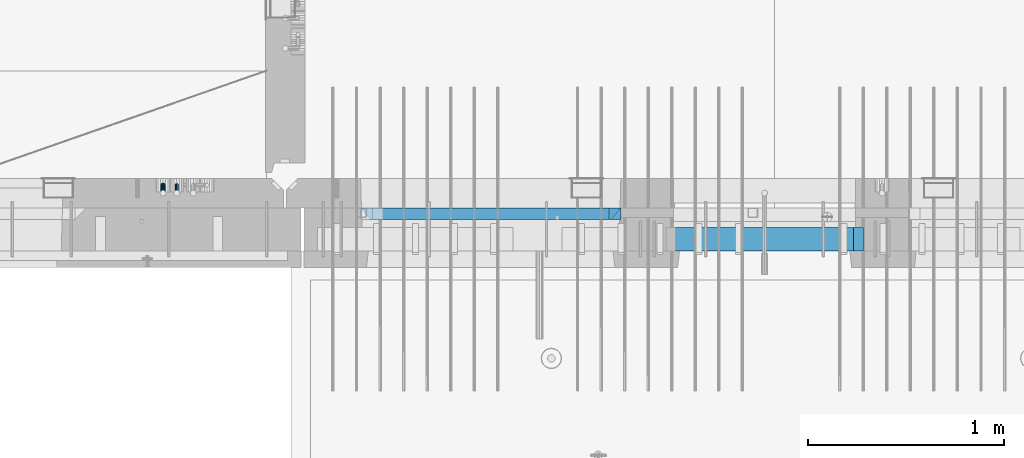
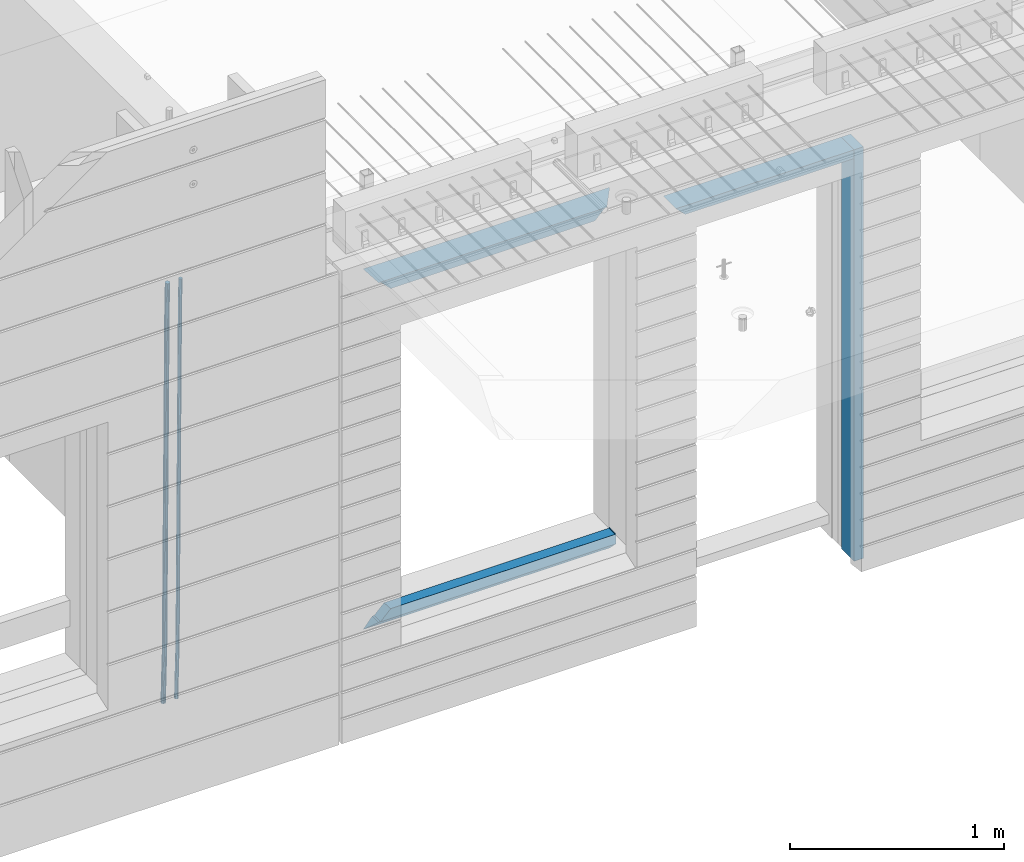
# One storey, part 79 of 309: 8 beams, 2 elements without a shape of their own.
"""IFC2X3 building model written with IfcOpenShell, lengths in millimetres."""

from ifc_helpers import new_model, si_unit, frame, origin_with_axes, place, context, subcontext, project, spatial, faceted_brep, material, type_object, element, aggregate, save


model = new_model("IFC2X3")

# Units and contexts
model_context = context("Model", 3, precision=1e-05, world=origin_with_axes())
body_context = subcontext(model_context, "Body", "Model", "MODEL_VIEW")
ifc_project = project(units=[si_unit("LENGTHUNIT", "METRE", prefix="MILLI"), si_unit("AREAUNIT", "SQUARE_METRE"), si_unit("VOLUMEUNIT", "CUBIC_METRE"), si_unit("MASSUNIT", "GRAM", prefix="KILO"), si_unit("TIMEUNIT", "SECOND"), si_unit("PLANEANGLEUNIT", "RADIAN"), si_unit("SOLIDANGLEUNIT", "STERADIAN"), si_unit("THERMODYNAMICTEMPERATUREUNIT", "DEGREE_CELSIUS"), si_unit("LUMINOUSINTENSITYUNIT", "LUMEN")], contexts=[model_context])

# Site, building, storey
site_placement = place(None, origin_with_axes())
site = spatial("IfcSite", under=ifc_project, at=site_placement, CompositionType="ELEMENT")
building_placement = place(site_placement, origin_with_axes())
building = spatial("IfcBuilding", under=site, at=building_placement, CompositionType="ELEMENT")
storey_placement = place(building_placement, origin_with_axes())
storey = spatial("IfcBuildingStorey", under=building, at=storey_placement, Name="7", CompositionType="ELEMENT", Elevation=0.0)

# Assembly, beams
assembly_1_placement = place(storey_placement, origin_with_axes())
assembly_1 = element("IfcElementAssembly", 1, at=assembly_1_placement, inside=storey, AssemblyPlace="NOTDEFINED", PredefinedType="REINFORCEMENT_UNIT")
ifc_material_1 = material()
beam_type_1 = type_object("IfcBeamType", Name="D20", PredefinedType="NOTDEFINED")
beam_1_placement = place(assembly_1_placement, frame((16104.9999999961, 7965.00000227913, 99990.0), z_axis=(0.00020576299992186, -0.999642804629538, -0.0267249099901004), x_axis=(-4.30000201928125e-08, -0.0267249099948059, 0.999642825806181)))
beam_1 = element("IfcBeam", 2, at=beam_1_placement, type_object=beam_type_1, material=ifc_material_1, Name="JM20", ObjectType="D20", context=body_context, shape_type="Brep", body=[
    faceted_brep([(0.0, -10.0, 0.0), (-4.19531716033816e-08, -7.07106781186667, -7.07106781187031), (60.4266690400545, -7.0710677960451, -7.07106780570757), (60.4266690441291, -9.99999998418934, 6.15546014159918e-09), (0.0, 0.0, -10.0), (60.426669036824, 1.58106558956206e-08, -9.99999999384454), (4.196772351861e-08, 7.07106781186303, -7.07106781186667), (60.4266690363438, 7.07106782768096, -7.07106780570757), (0.0, 10.0, 0.0), (60.4266690388904, 10.0000000158179, 6.15182216279209e-09), (4.196772351861e-08, 7.07106781185939, 7.07106781185939), (60.4266690429649, 7.07106782768096, 7.07106781802577), (0.0, 0.0, 10.0), (60.4266690461809, 1.58179318532348e-08, 10.0000000061555), (-4.19531716033816e-08, -7.07106781187031, 7.07106781185939), (60.4266690466611, -7.07106779605238, 7.07106781802213), (61.0378400410118, -7.07106779588503, -7.07106780564936), (60.991799419251, -9.99999998403655, 6.21366780251265e-09), (61.0569027789461, 1.5985278878361e-08, -9.99999999378269), (61.0378209396877, 7.07106782784831, -7.07106780564936), (60.9917724058905, 10.0000000159635, 6.21366780251265e-09), (60.9457317841297, 7.07106782781193, 7.0710678180767), (60.9266690461809, 1.59488990902901e-08, 10.0000000062028), (60.9457508854539, -7.07106779591413, 7.0710678180767), (61.6489592143771, -7.07106614513759, -7.06310863441468), (61.5568818710308, -9.9999984576425, 0.00735959856683621), (61.6870830769039, 1.71821739058942e-06, -9.99179257185824), (61.6489210170112, 7.07106947854481, -7.06310888312146), (61.556827851804, 10.0000015422847, 0.00735924683976918), (61.4647505084577, 7.07106922979438, 7.07782747982128), (61.4266266459163, 1.36643211590126e-06, 10.0065114172685), (61.464788705809, -7.07106639389531, 7.07782772852806), (176.543135720174, -7.07075579406956, -5.56673531796696), (176.451058376813, -9.99968810657447, 1.50373291501455), (176.581259582701, 0.000312069292704109, -8.49541925541052), (176.543097522794, 7.07137982961285, -5.56673556667374), (176.451004357587, 10.00031189336, 1.50373256329476), (176.35892701424, 7.07137958085514, 8.57420079627263), (176.320803151699, 0.000311717507429421, 11.5028847337162), (176.358965211621, -7.07075604281999, 8.57420104497578), (177.098753836006, -7.07075429323595, -5.55949898843028), (176.98362511232, -9.99968666800123, 1.510669025065), (177.146421932586, 0.000313595905026887, -8.48805862247536), (177.098706077581, 7.07138133041735, -5.55949936166144), (176.983557571715, 10.0003133318824, 1.51066849724157), (176.868428848029, 7.07138095712435, 8.58083651073321), (176.820760751449, 0.000313067976094317, 11.5093961447819), (176.868476606425, -7.07075466652896, 8.58083688396073), (177.654312950661, -7.07075204110879, -5.54863964998367), (177.516135294456, -9.99968450931192, 1.52107783331303), (177.711524267797, 0.000315886711177882, -8.47701274570863), (177.654255632195, 7.07138358250813, -5.54864021007961), (177.516054233929, 10.0003154905207, 1.5210770412159), (177.377876577739, 7.0713830223176, 8.59079452451624), (177.320665260588, 0.000315094497636892, 11.5191676202448), (177.377933896176, -7.07075260129932, 8.59079508461218), (299.436796249574, -7.07025836271714, -3.1681962331204), (299.298618593355, -9.99919083092027, 3.90152125031091), (299.494007566798, 0.000809565110102994, -6.09656932889993), (299.436738931283, 7.07187726089978, -3.16819679320906), (299.298537533061, 10.0008091689197, 3.90152045822106), (299.160359876842, 7.07187670072017, 10.9712379416487), (299.103148559603, 0.000808772889286047, 13.8996110374392), (299.160417195119, -7.07025892290039, 10.9712385017483), (299.98743051647, -7.07025613056248, -3.15743315966392), (299.971788958996, -9.99918809853989, 3.91467979818117), (299.993912075952, 0.000811591617093654, -6.08679785393178), (299.987423933868, 7.07187949325817, -3.1574327280432), (299.971753863239, 10.0008119014747, 3.91467990454839), (299.95611230444, 7.07187992653053, 10.9867922621015), (299.949630744944, 0.000812204350950196, 13.9161569563694), (299.956118887014, -7.07025569729012, 10.9867918304735), (300.538107039494, -7.07025785017686, -3.16575821840888), (300.644985195438, -9.99919020432935, 3.90450175465594), (300.493854948218, 0.000810030429420294, -6.09435592770024), (300.538151196495, 7.071877773491, -3.16575855385963), (300.645047642858, 10.0008097955724, 3.90450128024895), (300.751925798773, 7.07187744142357, 10.9747612533101), (300.796177890064, 0.000809560813650023, 13.9033589625978), (300.751881641787, -7.07025818224065, 10.9747615887682), (2293.36490490142, -7.07648090940347, -33.2930642912361), (2293.47178305736, -10.0054132635523, -26.2228043181785), (2293.32065281013, -0.00541302880083094, -36.2216620005347), (2293.36494905842, 7.06565471425711, -33.2930646266868), (2293.47184550477, 9.99458673634581, -26.2228047925819), (2293.57872366071, 7.06565438219332, -19.1525448195243), (2293.62297575199, -0.00541349841296324, -16.2239471102366), (2293.57867950371, -7.0764812414709, -19.1525444840736), (2294.0658245362, -7.07648309818615, -33.3036607065333), (2294.05312277409, -10.0054150789219, -26.2315929392535), (2294.10928714235, -0.00541549149056664, -36.2335844756526), (2294.15805078732, 7.06565223761572, -33.3050546393533), (2294.18355038921, 9.99458451388637, -26.2335642579346), (2294.17084862708, 7.06565253314329, -19.1614964906439), (2294.12738602093, -0.00541507354500936, -16.2315727215355), (2294.07862237596, -7.07648280265857, -19.1601025578348), (2294.76670261032, -7.08562269121467, -33.294332712383), (2294.63442802057, -10.0129954178956, -26.2238563411993), (2294.89787471293, -0.0156988342423574, -36.2230891548279), (2294.95110548967, 7.05531064255774, -33.2944998654275), (2294.89521307347, 9.98530428734011, -26.2240927312887), (2294.76293848372, 7.0579315606592, -19.1536163601049), (2294.63176638114, -0.0119922963167483, -16.2248599176673), (2294.57853560438, -7.08300177311321, -19.1534492070678), (2316.52657204497, -7.36937582653991, -33.0047303660212), (2316.39429745522, -10.2967485532172, -25.9342539948302), (2316.65774414754, -0.299451969567599, -35.9334868084661), (2316.7109749243, 6.7715575072325, -33.0048975190657), (2316.65508250811, 9.70155115201487, -25.9344903849269), (2316.52280791836, 6.7741784253376, -18.8640140137468), (2316.39163581574, -0.295745431634714, -15.9352575713092), (2316.33840503903, -7.36675490843481, -18.863846860706), (2317.16202064224, -7.37766220584308, -32.9962731735213), (2317.05438744847, -10.3053562613532, -25.9254688497131), (2317.23607125619, -0.306993473008333, -35.925789846493), (2317.23316144495, 6.76474808850253, -32.9979477328052), (2317.15499573652, 9.6950321815566, -25.9278370341635), (2317.04736254275, 6.7673381260538, -18.8570327103698), (2316.97331192881, -0.303330606784584, -15.9275160373909), (2316.97622174003, -7.37507216829545, -18.8553581510787), (2317.79752306276, -7.37578610372293, -32.9880110666527), (2317.71453320107, -10.3033876998124, -25.9168792378296), (2317.81444760226, -0.305295583297266, -35.918287695793), (2317.75539265381, 6.76628640723357, -32.9911928173897), (2317.65495180529, 9.69652304524061, -25.9213789128698), (2317.5719619436, 6.76892144914746, -18.8502470840467), (2317.55503740412, -0.301569071270933, -15.9199704549137), (2317.61409235255, -7.3731510618054, -18.847065333317), (2417.8183084176, -7.07752398473531, -31.6906369377139), (2417.73531855589, -10.0051255808248, -24.6195051088798), (2417.83523295709, -0.007033464313281, -34.6209135668432), (2417.77617800863, 7.06454852621755, -31.6938186884508), (2417.67573716014, 9.99478516423187, -24.6240047839383), (2417.59274729842, 7.06718356813872, -17.5528729551006), (2417.57582275895, -0.00330695228694822, -14.6225963259749), (2417.6348777074, -7.07488894281778, -17.5496912043673)], [[[0, 1, 2, 3]], [[1, 4, 5, 2]], [[4, 6, 7, 5]], [[6, 8, 9, 7]], [[8, 10, 11, 9]], [[10, 12, 13, 11]], [[12, 14, 15, 13]], [[14, 0, 3, 15]], [[14, 12, 10, 8, 6, 4, 1, 0]], [[3, 2, 16, 17]], [[2, 5, 18, 16]], [[5, 7, 19, 18]], [[7, 9, 20, 19]], [[9, 11, 21, 20]], [[11, 13, 22, 21]], [[13, 15, 23, 22]], [[15, 3, 17, 23]], [[17, 16, 24, 25]], [[16, 18, 26, 24]], [[18, 19, 27, 26]], [[19, 20, 28, 27]], [[20, 21, 29, 28]], [[21, 22, 30, 29]], [[22, 23, 31, 30]], [[23, 17, 25, 31]], [[25, 24, 32, 33]], [[24, 26, 34, 32]], [[26, 27, 35, 34]], [[27, 28, 36, 35]], [[28, 29, 37, 36]], [[29, 30, 38, 37]], [[30, 31, 39, 38]], [[31, 25, 33, 39]], [[33, 32, 40, 41]], [[32, 34, 42, 40]], [[34, 35, 43, 42]], [[35, 36, 44, 43]], [[36, 37, 45, 44]], [[37, 38, 46, 45]], [[38, 39, 47, 46]], [[39, 33, 41, 47]], [[41, 40, 48, 49]], [[40, 42, 50, 48]], [[42, 43, 51, 50]], [[43, 44, 52, 51]], [[44, 45, 53, 52]], [[45, 46, 54, 53]], [[46, 47, 55, 54]], [[47, 41, 49, 55]], [[49, 48, 56, 57]], [[48, 50, 58, 56]], [[50, 51, 59, 58]], [[51, 52, 60, 59]], [[52, 53, 61, 60]], [[53, 54, 62, 61]], [[54, 55, 63, 62]], [[55, 49, 57, 63]], [[57, 56, 64, 65]], [[56, 58, 66, 64]], [[58, 59, 67, 66]], [[59, 60, 68, 67]], [[60, 61, 69, 68]], [[61, 62, 70, 69]], [[62, 63, 71, 70]], [[63, 57, 65, 71]], [[65, 64, 72, 73]], [[64, 66, 74, 72]], [[66, 67, 75, 74]], [[67, 68, 76, 75]], [[68, 69, 77, 76]], [[69, 70, 78, 77]], [[70, 71, 79, 78]], [[71, 65, 73, 79]], [[73, 72, 80, 81]], [[72, 74, 82, 80]], [[74, 75, 83, 82]], [[75, 76, 84, 83]], [[76, 77, 85, 84]], [[77, 78, 86, 85]], [[78, 79, 87, 86]], [[79, 73, 81, 87]], [[81, 80, 88, 89]], [[80, 82, 90, 88]], [[82, 83, 91, 90]], [[83, 84, 92, 91]], [[84, 85, 93, 92]], [[85, 86, 94, 93]], [[86, 87, 95, 94]], [[87, 81, 89, 95]], [[89, 88, 96, 97]], [[88, 90, 98, 96]], [[90, 91, 99, 98]], [[91, 92, 100, 99]], [[92, 93, 101, 100]], [[93, 94, 102, 101]], [[94, 95, 103, 102]], [[95, 89, 97, 103]], [[97, 96, 104, 105]], [[96, 98, 106, 104]], [[98, 99, 107, 106]], [[99, 100, 108, 107]], [[100, 101, 109, 108]], [[101, 102, 110, 109]], [[102, 103, 111, 110]], [[103, 97, 105, 111]], [[105, 104, 112, 113]], [[104, 106, 114, 112]], [[106, 107, 115, 114]], [[107, 108, 116, 115]], [[108, 109, 117, 116]], [[109, 110, 118, 117]], [[110, 111, 119, 118]], [[111, 105, 113, 119]], [[113, 112, 120, 121]], [[112, 114, 122, 120]], [[114, 115, 123, 122]], [[115, 116, 124, 123]], [[116, 117, 125, 124]], [[117, 118, 126, 125]], [[118, 119, 127, 126]], [[119, 113, 121, 127]], [[121, 120, 128, 129]], [[120, 122, 130, 128]], [[122, 123, 131, 130]], [[123, 124, 132, 131]], [[124, 125, 133, 132]], [[125, 126, 134, 133]], [[126, 127, 135, 134]], [[127, 121, 129, 135]], [[130, 131, 132, 133, 134, 135, 129, 128]]]),
])
beam_type_2 = type_object("IfcBeamType", Name="D25", PredefinedType="NOTDEFINED")
beam_2_placement = place(assembly_1_placement, frame((16034.9999999961, 7965.00000227913, 99990.0), z_axis=(0.00020576299992186, -0.999642804629538, -0.0267249099901004), x_axis=(-4.30000201928125e-08, -0.0267249099948059, 0.999642825806181)))
beam_2 = element("IfcBeam", 3, at=beam_2_placement, type_object=beam_type_2, material=ifc_material_1, Name="JM25", ObjectType="D25", context=body_context, shape_type="Brep", body=[
    faceted_brep([(-7.41420080885291e-08, -12.5, -3.63797880709171e-12), (-6.42030499875546e-08, -10.8253175473074, -6.25000000000364), (60.4103898235917, -10.8253175318459, -6.2499999938409), (60.4103898269532, -12.4999999845422, 6.16273609921336e-09), (-3.70782800018787e-08, -6.25000000000364, -10.8253175473074), (60.4103898202884, -6.24999998454587, -10.8253175411446), (-1.45519152283669e-11, -3.63797880709171e-12, -12.5), (60.4103898179019, 1.54577719513327e-08, -12.4999999938373), (3.70637280866504e-08, 6.25, -10.8253175473074), (60.410389817087, 6.25000001545777, -10.825317541141), (6.42030499875546e-08, 10.8253175473001, -6.25000000000364), (60.410389818062, 10.8253175627578, -6.24999999383726), (7.41420080885291e-08, 12.4999999999927, 0.0), (60.4103898205503, 12.5000000154541, 6.16273609921336e-09), (6.42176019027829e-08, 10.8253175473001, 6.24999999999636), (60.4103898238973, 10.8253175627651, 6.2500000061591), (3.70928319171071e-08, 6.24999999999636, 10.8253175473037), (60.4103898272151, 6.25000001546141, 10.8253175534664), (1.45519152283669e-11, -3.63797880709171e-12, 12.4999999999964), (60.4103898296162, 1.54541339725256e-08, 12.5000000061591), (-3.7049176171422e-08, -6.25000000000364, 10.8253175473001), (60.4103898304165, -6.24999998454587, 10.8253175534701), (-6.41884980723262e-08, -10.8253175473074, 6.25), (60.4103898294561, -10.8253175318459, 6.25000000616637), (61.0324985728803, -10.8253175316895, -6.24999999377542), (60.991802792938, -12.4999999843931, 6.22458173893392e-09), (61.0622854283865, -6.24999998437852, -10.8253175410755), (61.0731819955545, 1.5628756955266e-08, -12.4999999937718), (61.0622685480339, 6.25000001562512, -10.8253175410791), (61.032469335245, 10.8253175629216, -6.24999999377178), (60.9917690322181, 12.5000000156033, 6.22458173893392e-09), (60.9510732522613, 10.8253175629034, 6.25000000621731), (60.9212863967696, 6.25000001558874, 10.8253175535247), (60.9103898296162, 1.55814632307738e-08, 12.5000000062137), (60.9213032771368, -6.24999998441126, 10.8253175535174), (60.9511024898966, -10.8253175317113, 6.25000000621731), (61.6545545670233, -10.8253158516927, -6.24189838219536), (61.573166454793, -12.499998414296, 0.00757164385504439), (61.7141257553885, -6.24999822394238, -10.8168280205282), (61.7359179680789, 1.80548886419274e-06, -12.491368569139), (61.7140919992817, 6.25000177601396, -10.8168282403167), (61.6544960997562, 10.8253192428383, -6.2418987628771), (61.5730989426083, 12.5000015856094, 0.0075712042817031), (61.4917108303925, 10.8253190230062, 6.25704123032847), (61.4321396420273, 6.25000139525582, 10.8319708686649), (61.4103474293224, 1.36582457344048e-06, 12.5065114172721), (61.4321733981196, -6.24999860470052, 10.8319710884571), (61.4917692976451, -10.8253160715249, 6.25704161101385), (176.524302641745, -10.8250056210964, -4.74584321979273), (176.442914529529, -12.4996881836996, 1.50362680625403), (176.583873830095, -6.24968799334965, -9.3207728581292), (176.605666042786, 0.000312036081595579, -10.9953134067364), (176.583840074018, 6.25031200660669, -9.32077307791769), (176.524244174492, 10.8256294734347, -4.74584360047811), (176.44284701733, 12.5003118162058, 1.50362636668069), (176.361458905099, 10.8256292535989, 7.75309639272746), (176.301887716749, 6.25031162585219, 12.3280260310676), (176.280095504058, 0.000311596420942806, 14.0025665796711), (176.301921472827, -6.24968837410415, 12.3280262508561), (176.361517372367, -10.8250058409321, 7.75309677341284), (177.085397012124, -10.8250041057399, -4.73853556792164), (176.983633547483, -12.4996867233749, 1.51066909103247), (177.159881729676, -6.24968643771717, -9.31327097355097), (177.187129580227, 0.000313606451527448, -10.987740468332), (177.159839524218, 6.25031356221734, -9.31327130338468), (177.085323910098, 10.8256309887511, -4.73853613920801), (176.983549136537, 12.5003132764905, 1.51066843136869), (176.881785671867, 10.8256306588555, 7.7598730903228), (176.80730095433, 6.25031299082912, 12.3346084959521), (176.780053103794, 0.000312946667690994, 14.0090779907332), (176.807343159802, -6.2496870091054, 12.3346088257895), (176.881858773908, -10.8250044356355, 7.7598736616128), (177.646431799818, -10.8250018318176, -4.72756919822132), (177.524295146417, -12.4996845320202, 1.52123723245313), (177.735828462886, -6.24968410334986, -9.30201312475765), (177.768531371941, 0.00031596292683389, -10.9763759912421), (177.735777808921, 6.25031589654827, -9.30201361973741), (177.646344064575, 10.8256332626152, -4.72757005553649), (177.524193838486, 12.5003154677688, 1.52123624250817), (177.402057185071, 10.8256327675663, 7.77004267317898), (177.312660521988, 6.2503150390985, 12.3444865997226), (177.279957612933, 0.00031497282179771, 14.0188494661961), (177.312711175953, -6.24968496079964, 12.3444870946951), (177.402144920314, -10.8250023268702, 7.77004353049415), (299.377443161706, -10.8245084454466, -2.34813158632096), (299.255306508276, -12.4991911456491, 3.90067484435349), (299.466839824803, -6.24919071697514, -6.92257551286093), (299.499542733873, 0.0008093492979242, -8.59693837933446), (299.466789170867, 6.250809282923, -6.92257600783341), (299.377355426492, 10.8261266489935, -2.34813244364341), (299.255205200388, 12.5008088541435, 3.90067385440125), (299.133068546944, 10.826126153941, 10.1494802850757), (299.043671883861, 6.25080842546959, 14.7239242116229), (299.010968974762, 0.000808359200163977, 16.3982870780892), (299.043722537797, -6.24919157442127, 14.7239247065918), (299.133156282158, -10.8245089404954, 10.1494811423981), (299.98561436501, -10.8245059804758, -2.33624385599614), (299.97179243555, -12.4991882411778, 3.91467976726199), (299.995742293278, -6.24918857328521, -6.91223722345239), (299.999447243041, 0.000811375455668895, -8.58716690387519), (299.995736475976, 6.25081142679483, -6.91223684201032), (299.985604289133, 10.8261291142808, -2.33624319533556), (299.971750386685, 12.5008117588586, 3.91467993563856), (299.957928457196, 10.8261294971744, 10.1656035610831), (299.947800528913, 6.25081208998381, 14.7415969285394), (299.944095579151, 0.00081214124293183, 16.4165266089549), (299.947806346216, -6.24918791008895, 14.7415965471009), (299.957938533058, -10.8245055975785, 10.1656029004225), (300.593832239858, -10.8245078794353, -2.34543881707941), (300.688302931099, -12.4991904788549, 3.90384712594823), (300.524685350189, -6.24919022474205, -6.92023371784308), (300.499390115292, 0.000809814544481924, -8.59472497713432), (300.524724372954, 6.25080977519247, -6.92023401429469), (300.593899829313, 10.8261272150703, -2.34543933054374), (300.688380976673, 12.5008095210287, 3.90384653304136), (300.782851667915, 10.8261269216127, 10.1531324760799), (300.851998557599, 6.25080926691589, 14.7279273768363), (300.877293792495, 0.000809227632998955, 16.4024186361276), (300.851959534804, -6.24919073302226, 14.7279276732806), (300.782784078474, -10.8245081728965, 10.153132989537), (2293.32930409742, -10.8307295605009, -32.4713622331001), (2293.42377478865, -12.5054121599169, -26.2220762900724), (2293.26015720774, -6.2554119058077, -37.0461571338565), (2293.23486197284, -0.00541186651753378, -38.7206483931477), (2293.26019623051, 6.24458809413409, -37.0461574303008), (2293.32937168686, 10.8199055340046, -32.4713627465644), (2293.42385283421, 12.4945878399631, -26.2220768829684), (2293.51832352545, 10.8199052405434, -19.972790939948), (2293.58747041514, 6.24458758585388, -15.3979960391844), (2293.61276565003, -0.00541245343265473, -13.7235047798931), (2293.58743139236, -6.25541241408428, -15.3979957427327), (2293.51825593603, -10.8307298539585, -19.9727904264691), (2294.0420846676, -10.8307317859326, -32.4821379598216), (2294.03681932652, -12.5054140739521, -26.2313442200393), (2294.06778164886, -6.2554144273563, -37.0583666982457), (2294.10702478497, -0.00541458957013674, -38.7338336404937), (2294.14929890928, 6.24458531819619, -37.0595987724118), (2294.18327670435, 10.8199028679592, -32.4842719748667), (2294.1998538474, 12.4945854171456, -26.2338083683717), (2294.19458850632, 10.819903129126, -19.9830146285858), (2294.16889152506, 6.24458577054975, -15.4067858901581), (2294.12964838895, -0.0054140672327776, -13.7313189479173), (2294.08737426462, -6.2554139749991, -15.4055538159919), (2294.05339646956, -10.8307315247621, -19.9808806135297), (2294.75482297382, -10.84002603931, -32.4726521173216), (2294.64982751427, -12.513407826169, -26.2231856868602), (2294.87535820232, -6.26594539088183, -37.0476186524102), (2294.97913588268, -0.0167870967634371, -38.7222267036377), (2295.0383488692, 6.23299192477134, -37.0477663960555), (2295.03713108998, 10.8087684320271, -32.4729080168181), (2294.97580884799, 12.4844668051373, -26.2234811741473), (2294.87081338844, 10.8110850182784, -19.9740147436787), (2294.7502781599, 6.23700436985018, -15.3990482086047), (2294.64650047956, -0.0121539242718427, -13.7244401573698), (2294.58728749304, -6.26193294580662, -15.3989004649666), (2294.58850527227, -10.8377094530588, -19.9737588441894), (2316.44667268227, -11.1228921988077, -32.1839550346631), (2316.34167722271, -12.7962739856739, -25.9344886042054), (2316.56720791078, -6.54881155039038, -36.7589215697517), (2316.67098559113, -0.299653256264719, -38.4335296209792), (2316.73019857766, 5.95012576527006, -36.759069313397), (2316.72898079845, 10.5259022725259, -32.1842109341669), (2316.66765855643, 12.2016006456361, -25.9347840914961), (2316.56266309689, 10.5282188587698, -19.6853176610275), (2316.44212786836, 5.95413821035254, -15.1103511259389), (2316.33835018802, -0.295020083769487, -13.4357430747186), (2316.27913720149, -6.54479910530426, -15.1102033823008), (2316.28035498071, -11.1205756125637, -19.685061761531), (2317.13234804722, -11.1318335458927, -32.1748293731798), (2317.04181141085, -12.8054038787741, -25.9251705100723), (2317.2154741603, -6.5572650749491, -36.7502937866229), (2317.26891617525, -0.307450393454928, -38.4255717558117), (2317.27835434731, 5.94297770185585, -36.7517739018112), (2317.24125972588, 10.5192220504723, -32.1773930078925), (2317.16757178486, 12.1950816748285, -25.9281307404563), (2317.0770351485, 10.5215113419545, -19.6784718773561), (2316.99390903539, 5.94694287101083, -15.1030074639057), (2316.94046702047, -0.302871810494253, -13.4277294947169), (2316.9310288484, -6.55329990579412, -15.1015273487101), (2316.96812346982, -11.1295442544142, -19.6759082426288), (2317.81808136747, -11.1298054502913, -32.1659056455355), (2317.74200467508, -12.803315894289, -25.9160547315114), (2317.86379538118, -6.55536082026447, -36.7418676070083), (2317.8668976831, -0.305700748642266, -38.417815303761), (2317.82655701396, 5.94458339541234, -36.7446799039099), (2317.75358262347, 10.5207330230332, -32.1707766866384), (2317.66752794063, 12.1965725370646, -25.9216793252963), (2317.59145124823, 10.5230620930706, -19.6718284112721), (2317.54573723453, 5.94861746304377, -15.0958664497994), (2317.54263493262, -0.301042608574789, -13.4199187530394), (2317.58297560175, -6.55132675263303, -15.0930541529051), (2317.65594999224, -11.1274763802539, -19.6669573701693), (2417.81884292323, -10.831603083323, -30.8687911350135), (2417.74276623082, -12.505113527317, -24.618940220982), (2417.86455693691, -6.25715845329614, -35.4447530964935), (2417.86765923884, -0.00749838167394046, -37.1207007932499), (2417.82731856969, 6.24278576237703, -35.4475653933878), (2417.75434417921, 10.8189353900088, -30.8736621761236), (2417.66828949639, 12.494774904033, -24.6245648147851), (2417.59221280397, 10.8212644600353, -18.3747139007501), (2417.54649879028, 6.2468198300121, -13.79875193927), (2417.54339648837, -0.00284024161010166, -12.1228042425173), (2417.5837371575, -6.25312438566107, -13.795939642383), (2417.65671154798, -10.8292740132893, -18.3698428596399)], [[[0, 1, 2, 3]], [[1, 4, 5, 2]], [[4, 6, 7, 5]], [[6, 8, 9, 7]], [[8, 10, 11, 9]], [[10, 12, 13, 11]], [[12, 14, 15, 13]], [[14, 16, 17, 15]], [[16, 18, 19, 17]], [[18, 20, 21, 19]], [[20, 22, 23, 21]], [[22, 0, 3, 23]], [[22, 20, 18, 16, 14, 12, 10, 8, 6, 4, 1, 0]], [[3, 2, 24, 25]], [[2, 5, 26, 24]], [[5, 7, 27, 26]], [[7, 9, 28, 27]], [[9, 11, 29, 28]], [[11, 13, 30, 29]], [[13, 15, 31, 30]], [[15, 17, 32, 31]], [[17, 19, 33, 32]], [[19, 21, 34, 33]], [[21, 23, 35, 34]], [[23, 3, 25, 35]], [[25, 24, 36, 37]], [[24, 26, 38, 36]], [[26, 27, 39, 38]], [[27, 28, 40, 39]], [[28, 29, 41, 40]], [[29, 30, 42, 41]], [[30, 31, 43, 42]], [[31, 32, 44, 43]], [[32, 33, 45, 44]], [[33, 34, 46, 45]], [[34, 35, 47, 46]], [[35, 25, 37, 47]], [[37, 36, 48, 49]], [[36, 38, 50, 48]], [[38, 39, 51, 50]], [[39, 40, 52, 51]], [[40, 41, 53, 52]], [[41, 42, 54, 53]], [[42, 43, 55, 54]], [[43, 44, 56, 55]], [[44, 45, 57, 56]], [[45, 46, 58, 57]], [[46, 47, 59, 58]], [[47, 37, 49, 59]], [[49, 48, 60, 61]], [[48, 50, 62, 60]], [[50, 51, 63, 62]], [[51, 52, 64, 63]], [[52, 53, 65, 64]], [[53, 54, 66, 65]], [[54, 55, 67, 66]], [[55, 56, 68, 67]], [[56, 57, 69, 68]], [[57, 58, 70, 69]], [[58, 59, 71, 70]], [[59, 49, 61, 71]], [[61, 60, 72, 73]], [[60, 62, 74, 72]], [[62, 63, 75, 74]], [[63, 64, 76, 75]], [[64, 65, 77, 76]], [[65, 66, 78, 77]], [[66, 67, 79, 78]], [[67, 68, 80, 79]], [[68, 69, 81, 80]], [[69, 70, 82, 81]], [[70, 71, 83, 82]], [[71, 61, 73, 83]], [[73, 72, 84, 85]], [[72, 74, 86, 84]], [[74, 75, 87, 86]], [[75, 76, 88, 87]], [[76, 77, 89, 88]], [[77, 78, 90, 89]], [[78, 79, 91, 90]], [[79, 80, 92, 91]], [[80, 81, 93, 92]], [[81, 82, 94, 93]], [[82, 83, 95, 94]], [[83, 73, 85, 95]], [[85, 84, 96, 97]], [[84, 86, 98, 96]], [[86, 87, 99, 98]], [[87, 88, 100, 99]], [[88, 89, 101, 100]], [[89, 90, 102, 101]], [[90, 91, 103, 102]], [[91, 92, 104, 103]], [[92, 93, 105, 104]], [[93, 94, 106, 105]], [[94, 95, 107, 106]], [[95, 85, 97, 107]], [[97, 96, 108, 109]], [[96, 98, 110, 108]], [[98, 99, 111, 110]], [[99, 100, 112, 111]], [[100, 101, 113, 112]], [[101, 102, 114, 113]], [[102, 103, 115, 114]], [[103, 104, 116, 115]], [[104, 105, 117, 116]], [[105, 106, 118, 117]], [[106, 107, 119, 118]], [[107, 97, 109, 119]], [[109, 108, 120, 121]], [[108, 110, 122, 120]], [[110, 111, 123, 122]], [[111, 112, 124, 123]], [[112, 113, 125, 124]], [[113, 114, 126, 125]], [[114, 115, 127, 126]], [[115, 116, 128, 127]], [[116, 117, 129, 128]], [[117, 118, 130, 129]], [[118, 119, 131, 130]], [[119, 109, 121, 131]], [[121, 120, 132, 133]], [[120, 122, 134, 132]], [[122, 123, 135, 134]], [[123, 124, 136, 135]], [[124, 125, 137, 136]], [[125, 126, 138, 137]], [[126, 127, 139, 138]], [[127, 128, 140, 139]], [[128, 129, 141, 140]], [[129, 130, 142, 141]], [[130, 131, 143, 142]], [[131, 121, 133, 143]], [[133, 132, 144, 145]], [[132, 134, 146, 144]], [[134, 135, 147, 146]], [[135, 136, 148, 147]], [[136, 137, 149, 148]], [[137, 138, 150, 149]], [[138, 139, 151, 150]], [[139, 140, 152, 151]], [[140, 141, 153, 152]], [[141, 142, 154, 153]], [[142, 143, 155, 154]], [[143, 133, 145, 155]], [[145, 144, 156, 157]], [[144, 146, 158, 156]], [[146, 147, 159, 158]], [[147, 148, 160, 159]], [[148, 149, 161, 160]], [[149, 150, 162, 161]], [[150, 151, 163, 162]], [[151, 152, 164, 163]], [[152, 153, 165, 164]], [[153, 154, 166, 165]], [[154, 155, 167, 166]], [[155, 145, 157, 167]], [[157, 156, 168, 169]], [[156, 158, 170, 168]], [[158, 159, 171, 170]], [[159, 160, 172, 171]], [[160, 161, 173, 172]], [[161, 162, 174, 173]], [[162, 163, 175, 174]], [[163, 164, 176, 175]], [[164, 165, 177, 176]], [[165, 166, 178, 177]], [[166, 167, 179, 178]], [[167, 157, 169, 179]], [[169, 168, 180, 181]], [[168, 170, 182, 180]], [[170, 171, 183, 182]], [[171, 172, 184, 183]], [[172, 173, 185, 184]], [[173, 174, 186, 185]], [[174, 175, 187, 186]], [[175, 176, 188, 187]], [[176, 177, 189, 188]], [[177, 178, 190, 189]], [[178, 179, 191, 190]], [[179, 169, 181, 191]], [[181, 180, 192, 193]], [[180, 182, 194, 192]], [[182, 183, 195, 194]], [[183, 184, 196, 195]], [[184, 185, 197, 196]], [[185, 186, 198, 197]], [[186, 187, 199, 198]], [[187, 188, 200, 199]], [[188, 189, 201, 200]], [[189, 190, 202, 201]], [[190, 191, 203, 202]], [[191, 181, 193, 203]], [[194, 195, 196, 197, 198, 199, 200, 201, 202, 203, 193, 192]]]),
])
aggregate(assembly_1, [beam_1, beam_2])

assembly_2_placement = place(storey_placement, origin_with_axes())
assembly_2 = element("IfcElementAssembly", 4, at=assembly_2_placement, inside=storey, AssemblyPlace="NOTDEFINED", PredefinedType="REINFORCEMENT_UNIT")
ifc_material_2 = material(Name="CONCRETE/C35/45")
beam_type_3 = type_object("IfcBeamType", PredefinedType="NOTDEFINED")
beam_3_placement = place(assembly_2_placement, frame((17044.9994828029, 7820.0, 102145.0), z_axis=(0.0, 0.0, -1.0), x_axis=(1.0, 0.0, 0.0)))
beam_3 = element("IfcBeam", 5, at=beam_3_placement, type_object=beam_type_3, material=ifc_material_2, Name="SK", context=body_context, shape_type="Brep", body=[
    faceted_brep([(0.0, -30.0, -30.0), (49.817662327685, -30.0, 30.0), (49.817662327685, 30.0, 30.0), (1330.00114440918, -30.0, -30.0), (1280.18348208149, -30.0, 30.0), (1280.18348208149, 30.0, 30.0)], [[[0, 1, 2]], [[1, 0, 3, 4]], [[2, 1, 4, 5]], [[0, 2, 5, 3]], [[4, 3, 5]]]),
])
beam_4_placement = place(assembly_2_placement, frame((17104.9994828029, 7820.0, 102085.0), z_axis=(0.0, 0.0, -1.0), x_axis=(1.0, 0.0, 0.0)))
beam_4 = element("IfcBeam", 6, at=beam_4_placement, type_object=beam_type_3, material=ifc_material_2, Name="SK", context=body_context, shape_type="Brep", body=[
    faceted_brep([(0.0, -30.0, -30.0), (53.0959879499314, -30.0, 24.0540540540678), (54.6888675884184, 30.0, 25.6756756756804), (0.0, 30.0, -30.0), (1210.00114440918, -30.0, -30.0), (1156.90515645927, -30.0, 24.0540540540678), (1155.31227682078, 30.0, 25.6756756756804), (1210.00114440918, 30.0, -30.0)], [[[0, 1, 2, 3]], [[1, 0, 4, 5]], [[2, 1, 5, 6]], [[3, 2, 6, 7]], [[0, 3, 7, 4]], [[6, 5, 4, 7]]]),
])
beam_5_placement = place(assembly_2_placement, frame((18375.0006272121, 7820.0, 100150.0), z_axis=(0.0, 0.0, 1.0), x_axis=(-1.0, 3.00000001838171e-08, 0.0)))
beam_5 = element("IfcBeam", 7, at=beam_5_placement, type_object=beam_type_3, material=ifc_material_2, Name="SK", context=body_context, shape_type="Brep", body=[
    faceted_brep([(0.0, -30.0, 30.0), (-5.28234522789717e-09, 30.0, 30.0), (0.0, -30.0, -30.0), (1280.18348208149, -30.0, 30.0), (1280.18348208149, 30.0, 30.0), (1330.00114440918, -30.0, -30.0)], [[[0, 1, 2]], [[1, 0, 3, 4]], [[2, 1, 4, 5]], [[0, 2, 5, 3]], [[3, 5, 4]]]),
])
beam_6_placement = place(assembly_2_placement, frame((18375.0006272121, 7820.0, 100210.0), z_axis=(0.0, 0.0, 1.0), x_axis=(-1.0, 3.00000001838171e-08, 0.0)))
beam_6 = element("IfcBeam", 8, at=beam_6_placement, type_object=beam_type_3, material=ifc_material_2, Name="SK", context=body_context, shape_type="Brep", body=[
    faceted_brep([(0.0, -30.0, -30.0), (0.0, -30.0, 30.0), (-5.28234522789717e-09, 30.0, 30.0), (0.0, 30.0, -30.0), (4.05405405405327, -30.0, 30.0), (5.67567567567312, 30.0, 30.0), (4.05405405404963, -30.0, 24.0540540540533), (5.67567567567312, 30.0, 25.6756756756804), (1215.31227682077, 30.0, 25.6756756756804), (1270.00114440918, 30.0, -30.0), (1270.00114440918, -30.0, -30.0), (1216.90515645926, -30.0, 24.0540540540678)], [[[0, 1, 2, 3]], [[2, 1, 4, 5]], [[4, 6, 7, 5]], [[3, 2, 5, 7, 8, 9]], [[0, 3, 9, 10]], [[6, 4, 1, 0, 10, 11]], [[7, 6, 11, 8]], [[10, 9, 8, 11]]]),
])
ifc_material_3 = material(Name="TIMBER")
beam_type_4 = type_object("IfcBeamType", Name="50X120", PredefinedType="NOTDEFINED")
beam_7_placement = place(assembly_2_placement, frame((18604.9998642727, 7690.0, 102080.0), z_axis=(0.0, 0.0, -1.0), x_axis=(1.0, 0.0, 0.0)))
beam_7 = element("IfcBeam", 9, at=beam_7_placement, type_object=beam_type_4, material=ifc_material_3, ObjectType="50X120", context=body_context, shape_type="Brep", body=[
    faceted_brep([(1009.99961853027, -60.0, 25.0), (1009.99961853027, -60.0, -25.0), (1009.99961853027, 60.0, -25.0), (1009.99961853027, 60.0, 25.0), (50.0000000000036, -60.0, 25.0), (0.0, -60.0, -25.0), (0.0, 60.0, -25.0), (50.0000000000036, 60.0, 25.0)], [[[0, 1, 2, 3]], [[1, 0, 4, 5]], [[2, 1, 5, 6]], [[3, 2, 6, 7]], [[0, 3, 7, 4]], [[6, 5, 4, 7]]]),
])
beam_8_placement = place(assembly_2_placement, frame((19589.9994828029, 7690.0, 102105.0), z_axis=(-1.0, 3.00000001838171e-08, 0.0), x_axis=(0.0, 0.0, -1.0)))
beam_8 = element("IfcBeam", 10, at=beam_8_placement, type_object=beam_type_4, material=ifc_material_3, ObjectType="50X120", context=body_context, shape_type="Brep", body=[
    faceted_brep([(0.0, 60.0, -25.0), (0.0, 60.0, 25.0), (2345.0, 60.0, 25.0), (2345.0, 60.0, -25.0), (0.0, -60.0, 25.0), (2345.0, -60.0, 25.0), (0.0, -60.0, -25.0), (2345.0, -60.0, -25.0)], [[[0, 1, 2, 3]], [[1, 4, 5, 2]], [[4, 6, 7, 5]], [[6, 0, 3, 7]], [[5, 7, 3, 2]], [[6, 4, 1, 0]]]),
])
aggregate(assembly_2, [beam_7, beam_8, beam_3, beam_4, beam_5, beam_6])

save(model, "model.ifc")
